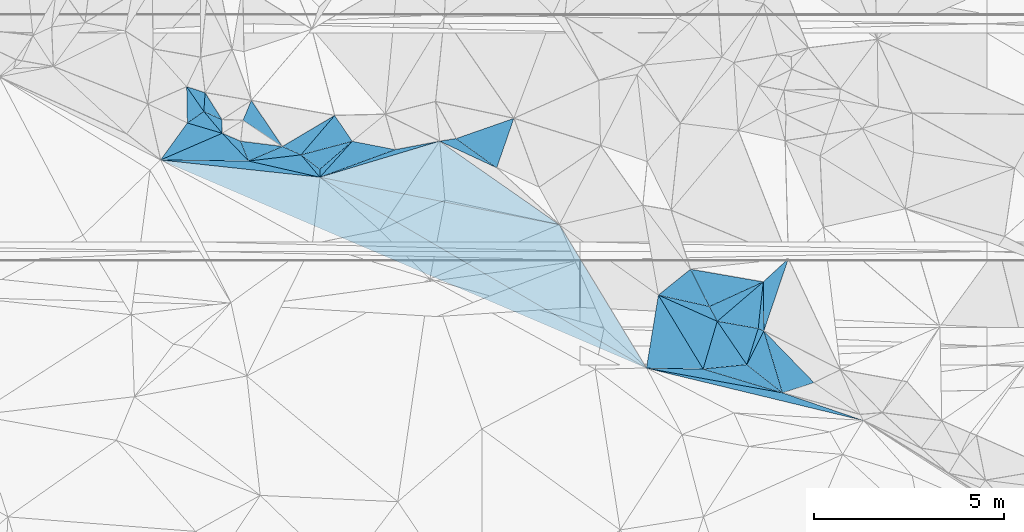
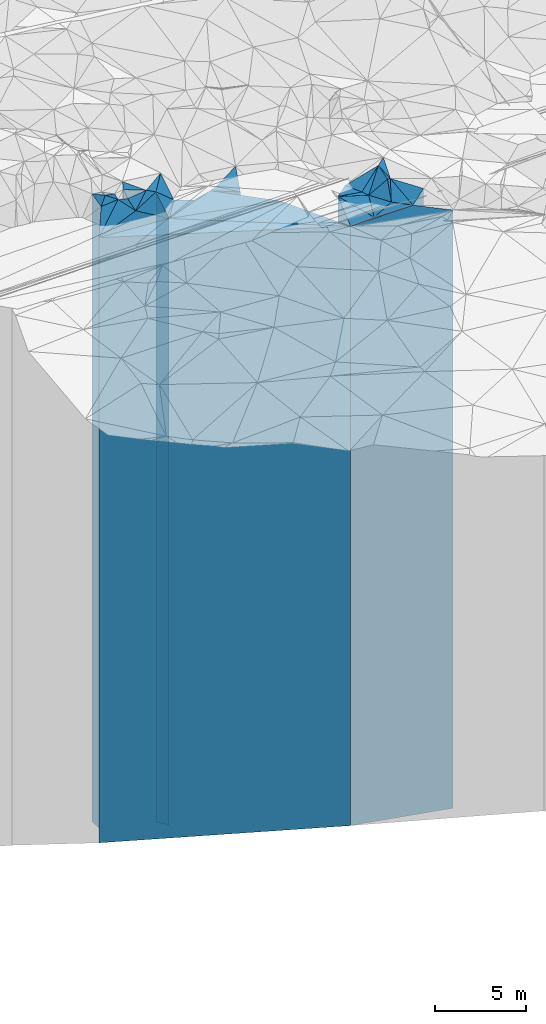
# One storey, part 203 of 275: 42 plates.
"""IFC2X3 building model written with IfcOpenShell, lengths in millimetres."""

from ifc_helpers import new_model, si_unit, frame, origin_with_axes, place, context, subcontext, project, spatial, faceted_brep, material, type_object, element, save


model = new_model("IFC2X3")

# Units and contexts
model_context = context("Model", 3, precision=1e-05, world=origin_with_axes())
body_context = subcontext(model_context, "Body", "Model", "MODEL_VIEW")
ifc_project = project(units=[si_unit("LENGTHUNIT", "METRE", prefix="MILLI"), si_unit("AREAUNIT", "SQUARE_METRE"), si_unit("VOLUMEUNIT", "CUBIC_METRE"), si_unit("MASSUNIT", "GRAM", prefix="KILO"), si_unit("TIMEUNIT", "SECOND"), si_unit("PLANEANGLEUNIT", "RADIAN"), si_unit("SOLIDANGLEUNIT", "STERADIAN"), si_unit("THERMODYNAMICTEMPERATUREUNIT", "DEGREE_CELSIUS"), si_unit("LUMINOUSINTENSITYUNIT", "LUMEN")], contexts=[model_context])

# Site, building, storey
site_placement = place(None, origin_with_axes())
site = spatial("IfcSite", under=ifc_project, at=site_placement, CompositionType="ELEMENT")
building_placement = place(site_placement, origin_with_axes())
building = spatial("IfcBuilding", under=site, at=building_placement, Name="Undefined", CompositionType="ELEMENT")
storey_placement = place(building_placement, origin_with_axes())
storey = spatial("IfcBuildingStorey", under=building, at=storey_placement, Name="Undefined", CompositionType="ELEMENT", Elevation=0.0)

# Plates
ifc_material = material()
plate_type_1 = type_object("IfcPlateType", PredefinedType="NOTDEFINED")
plate_1_placement = place(storey_placement, frame((-116440.557137259, 57306.797620916, 27989.0), z_axis=(0.0998657489693365, -0.995000920694445, 0.0), x_axis=(-0.995000920694446, -0.0998657489693296, 0.0)))
element("IfcPlate", 1, at=plate_1_placement, inside=storey, type_object=plate_type_1, material=ifc_material, Name="00", context=body_context, shape_type="Brep", body=[
    faceted_brep([(1.45519152283669e-11, -20711.0, 0.0), (-861.923767089815, -20621.0, 833.239074707031), (-861.923767089815, 20161.0, 833.239074707031), (1.45519152283669e-11, 20161.0, 0.0), (1157.41088867189, -20161.0, 1.68802216649055e-09), (1157.41088867189, 20161.0, 1.68802216649055e-09)], [[[0, 1, 2, 3]], [[1, 4, 5, 2]], [[4, 0, 3, 5]], [[5, 3, 2]], [[4, 1, 0]]]),
])
plate_type_2 = type_object("IfcPlateType", PredefinedType="NOTDEFINED")
plate_2_placement = place(storey_placement, frame((-119085.105449758, 57214.4654874976, 27906.0), z_axis=(0.234761072015638, 0.972053105064774, 0.0), x_axis=(0.972053105064773, -0.234761072015644, 0.0)))
element("IfcPlate", 2, at=plate_2_placement, inside=storey, type_object=plate_type_2, material=ifc_material, Name="00", context=body_context, shape_type="Brep", body=[
    faceted_brep([(-1.45519152283669e-11, -20150.0, 3.63797880709171e-12), (3637.92602539061, -20704.0, 209.225769042976), (3637.92602539061, 20078.0, 209.225769042976), (2.91038304567337e-11, 20078.0, -1.45519152283669e-11), (5883.48193359374, -20078.0, -1.29148247651756e-09), (5883.48193359374, 20078.0, -1.29148247651756e-09)], [[[0, 1, 2, 3]], [[1, 4, 5, 2]], [[4, 0, 3, 5]], [[5, 3, 2]], [[4, 1, 0]]]),
])
plate_type_3 = type_object("IfcPlateType", PredefinedType="NOTDEFINED")
plate_3_placement = place(storey_placement, frame((-115991.097209185, 58194.3705886519, 28219.0), z_axis=(0.892134515534765, -0.451769859764406, 0.0), x_axis=(-0.451769859764408, -0.892134515534764, 0.0)))
element("IfcPlate", 3, at=plate_3_placement, inside=storey, type_object=plate_type_3, material=ifc_material, Name="00", context=body_context, shape_type="Brep", body=[
    faceted_brep([(-6.59383658785373e-12, -21371.0, 1.45519152283669e-11), (1232.70288085937, -20391.0, 1175.00793457033), (1232.70288085937, 20391.0, 1175.00793457033), (-6.59383658785373e-12, 20391.0, 1.45519152283669e-11), (994.886901855462, -20481.0, 2.34285835176706e-09), (994.886901855462, 20391.0, 2.34285835176706e-09)], [[[0, 1, 2, 3]], [[1, 4, 5, 2]], [[4, 0, 3, 5]], [[5, 3, 2]], [[4, 1, 0]]]),
])
plate_type_4 = type_object("IfcPlateType", PredefinedType="NOTDEFINED")
plate_4_placement = place(storey_placement, frame((-118771.346950045, 59140.8965409895, 27942.0), z_axis=(0.986994799394878, -0.160752188064314, 0.0), x_axis=(-0.160752188064311, -0.986994799394879, 0.0)))
element("IfcPlate", 4, at=plate_4_placement, inside=storey, type_object=plate_type_4, material=ifc_material, Name="00", context=body_context, shape_type="Brep", body=[
    faceted_brep([(0.0, -20838.0, 0.0), (1734.77526855469, -20208.0, 1477.24572753906), (1734.77526855469, 20114.0, 1477.24572753906), (0.0, 20114.0, 0.0), (1951.81481933593, -20114.0, -2.79396772384644e-09), (1951.81481933593, 20114.0, -2.79396772384644e-09)], [[[0, 1, 2, 3]], [[1, 4, 5, 2]], [[4, 0, 3, 5]], [[5, 3, 2]], [[4, 1, 0]]]),
])
plate_type_5 = type_object("IfcPlateType", PredefinedType="NOTDEFINED")
plate_5_placement = place(storey_placement, frame((-115991.097209185, 58194.3705886519, 28709.0), z_axis=(-0.947058018121833, 0.321062471041301, 0.0), x_axis=(0.321062471041303, 0.947058018121832, 0.0)))
element("IfcPlate", 5, at=plate_5_placement, inside=storey, type_object=plate_type_5, material=ifc_material, Name="00", context=body_context, shape_type="Brep", body=[
    faceted_brep([(3.63797880709171e-12, -20881.0, 0.0), (1221.30859375, -20971.0, 429.657073974609), (1221.30859375, 20881.0, 429.657073974609), (3.63797880709171e-12, 20881.0, 0.0), (2009.97509765625, -20931.0, 1.78988557308912e-09), (2009.97509765625, 20881.0, 1.78988557308912e-09)], [[[0, 1, 2, 3]], [[1, 4, 5, 2]], [[4, 0, 3, 5]], [[5, 3, 2]], [[4, 1, 0]]]),
])
plate_type_6 = type_object("IfcPlateType", PredefinedType="NOTDEFINED")
plate_6_placement = place(storey_placement, frame((-117924.26484308, 59821.5961105942, 28309.0), z_axis=(0.891201122205586, 0.453608377104638, 0.0), x_axis=(0.453608377104646, -0.891201122205583, 0.0)))
element("IfcPlate", 6, at=plate_6_placement, inside=storey, type_object=plate_type_6, material=ifc_material, Name="00", context=body_context, shape_type="Brep", body=[
    faceted_brep([(-1.45519152283669e-11, -20511.0, 0.0), (1166.62939453122, -21371.0, 1558.77380371091), (1166.62939453122, 20481.0, 1558.77380371091), (-1.45519152283669e-11, 20481.0, 0.0), (1101.63513183592, -20481.0, 5.12227416038513e-09), (1101.63513183592, 20481.0, 5.12227416038513e-09)], [[[0, 1, 2, 3]], [[1, 4, 5, 2]], [[4, 0, 3, 5]], [[5, 3, 2]], [[4, 1, 0]]]),
])
plate_type_7 = type_object("IfcPlateType", PredefinedType="NOTDEFINED")
plate_7_placement = place(storey_placement, frame((-117924.26484308, 59821.5961105942, 28304.0), z_axis=(0.626395911836807, -0.77950507479691, 0.0), x_axis=(-0.779505074796912, -0.626395911836803, 0.0)))
element("IfcPlate", 7, at=plate_7_placement, inside=storey, type_object=plate_type_7, material=ifc_material, Name="00", context=body_context, shape_type="Brep", body=[
    faceted_brep([(1.45519152283669e-11, -20516.0, 1.45519152283669e-11), (225.4548187256, -20486.0, 1078.31823730472), (225.4548187256, 20476.0, 1078.31823730472), (0.0, 20476.0, 0.0), (1086.69226074221, -20476.0, 1.58615875989199e-09), (1086.69226074221, 20476.0, 1.58615875989199e-09)], [[[0, 1, 2, 3]], [[1, 4, 5, 2]], [[4, 0, 3, 5]], [[5, 3, 2]], [[4, 1, 0]]]),
])
plate_type_8 = type_object("IfcPlateType", PredefinedType="NOTDEFINED")
plate_8_placement = place(storey_placement, frame((-127694.000190885, 62455.7508581103, 28219.0), z_axis=(-0.654003369907349, 0.756491633892822, 0.0), x_axis=(0.756491633892824, 0.654003369907346, 0.0)))
element("IfcPlate", 8, at=plate_8_placement, inside=storey, type_object=plate_type_8, material=ifc_material, Name="00", context=body_context, shape_type="Brep", body=[
    faceted_brep([(0.0, -20391.0, 1.45519152283669e-11), (-126.185279846184, -21931.0, 613.658935546919), (-126.185279846184, 20391.0, 613.658935546919), (-6.59383658785373e-12, 20391.0, 1.45519152283669e-11), (1129.29187011719, -20691.0, 5.10772224515677e-09), (1129.29187011719, 20391.0, 5.10772224515677e-09)], [[[0, 1, 2, 3]], [[1, 4, 5, 2]], [[4, 0, 3, 5]], [[5, 3, 2]], [[4, 1, 0]]]),
])
plate_type_9 = type_object("IfcPlateType", PredefinedType="NOTDEFINED")
plate_9_placement = place(storey_placement, frame((-127694.000190885, 62455.7508581103, 28184.0), z_axis=(-0.609263113863359, -0.792968131822159, 0.0), x_axis=(-0.792968131822159, 0.609263113863359, 0.0)))
element("IfcPlate", 9, at=plate_9_placement, inside=storey, type_object=plate_type_9, material=ifc_material, Name="00", context=body_context, shape_type="Brep", body=[
    faceted_brep([(0.0, -20426.0, -1.45519152283669e-11), (-127.933326721191, -20356.0, 164.326095581055), (-127.933326721191, 20356.0, 164.326095581055), (0.0, 20356.0, -1.45519152283669e-11), (626.498229980469, -21966.0, -1.60071067512035e-09), (626.498229980469, 20356.0, -1.60071067512035e-09)], [[[0, 1, 2, 3]], [[1, 4, 5, 2]], [[4, 0, 3, 5]], [[5, 3, 2]], [[4, 1, 0]]]),
])
plate_type_10 = type_object("IfcPlateType", PredefinedType="NOTDEFINED")
plate_10_placement = place(storey_placement, frame((-123031.448124271, 62494.5867451311, 28184.0), z_axis=(-0.945001377387409, 0.327066349134086, 0.0), x_axis=(0.32706634913408, 0.945001377387411, 0.0)))
element("IfcPlate", 10, at=plate_10_placement, inside=storey, type_object=plate_type_10, material=ifc_material, Name="00", context=body_context, shape_type="Brep", body=[
    faceted_brep([(-1.09139364212751e-11, -20356.0, 0.0), (378.040496826154, -20626.0, 1267.11694335938), (378.040496826154, 20356.0, 1267.11694335938), (0.0, 20356.0, -1.45519152283669e-11), (1379.74633789061, -21146.0, 2.56113708019257e-09), (1379.74633789061, 20356.0, 2.56113708019257e-09)], [[[0, 1, 2, 3]], [[1, 4, 5, 2]], [[4, 0, 3, 5]], [[5, 3, 2]], [[4, 1, 0]]]),
])
plate_type_11 = type_object("IfcPlateType", PredefinedType="NOTDEFINED")
plate_11_placement = place(storey_placement, frame((-125703.944165359, 62974.8626141599, 28184.0), z_axis=(-0.189709514984272, -0.981840261918624, 0.0), x_axis=(-0.981840261918623, 0.189709514984278, 0.0)))
element("IfcPlate", 11, at=plate_11_placement, inside=storey, type_object=plate_type_11, material=ifc_material, Name="00", context=body_context, shape_type="Brep", body=[
    faceted_brep([(0.0, -20456.0, 1.45519152283669e-11), (1814.62451171875, -20356.0, 1091.43383789063), (1814.62451171875, 20356.0, 1091.43383789063), (0.0, 20356.0, -1.45519152283669e-11), (1156.7626953125, -20726.0, -8.22183210402727e-10), (1156.7626953125, 20356.0, -8.22183210402727e-10)], [[[0, 1, 2, 3]], [[1, 4, 5, 2]], [[4, 0, 3, 5]], [[5, 3, 2]], [[4, 1, 0]]]),
])
plate_type_12 = type_object("IfcPlateType", PredefinedType="NOTDEFINED")
plate_12_placement = place(storey_placement, frame((-127694.000190885, 62455.7508581103, 28184.0), z_axis=(0.999979630369262, 0.00638269900235852, 0.0), x_axis=(0.00638269900233659, -0.999979630369262, 0.0)))
element("IfcPlate", 12, at=plate_12_placement, inside=storey, type_object=plate_type_12, material=ifc_material, Name="00", context=body_context, shape_type="Brep", body=[
    faceted_brep([(0.0, -20426.0, -1.45519152283669e-11), (-733.092895507791, -20726.0, 858.996398925781), (-733.092895507791, 20356.0, 858.996398925781), (0.0, 20356.0, -1.45519152283669e-11), (208.254653930671, -20356.0, 7.27595761418343e-11), (208.254653930671, 20356.0, 7.27595761418343e-11)], [[[0, 1, 2, 3]], [[1, 4, 5, 2]], [[4, 0, 3, 5]], [[5, 3, 2]], [[4, 1, 0]]]),
])
plate_type_13 = type_object("IfcPlateType", PredefinedType="NOTDEFINED")
plate_13_placement = place(storey_placement, frame((-128681.802003754, 63057.7039945683, 29054.0), z_axis=(-0.828176731175873, -0.560467039119025, 0.0), x_axis=(-0.560467039119019, 0.828176731175876, 0.0)))
element("IfcPlate", 13, at=plate_13_placement, inside=storey, type_object=plate_type_13, material=ifc_material, Name="00", context=body_context, shape_type="Brep", body=[
    faceted_brep([(0.0, -21236.0, 1.45519152283669e-11), (1152.33959960938, -21226.0, 472.772216796875), (1152.33959960938, 21226.0, 472.772216796875), (0.0, 21226.0, 1.45519152283669e-11), (1463.28393554688, -21376.0, -2.13913153856993e-09), (1463.28393554688, 21226.0, -2.13913153856993e-09)], [[[0, 1, 2, 3]], [[1, 4, 5, 2]], [[4, 0, 3, 5]], [[5, 3, 2]], [[4, 1, 0]]]),
])
plate_type_14 = type_object("IfcPlateType", PredefinedType="NOTDEFINED")
plate_14_placement = place(storey_placement, frame((-131203.971896482, 64632.2385391942, 28899.0), z_axis=(0.821758074128353, 0.569836527089006, 0.0), x_axis=(0.56983652708901, -0.821758074128351, 0.0)))
element("IfcPlate", 14, at=plate_14_placement, inside=storey, type_object=plate_type_14, material=ifc_material, Name="00", context=body_context, shape_type="Brep", body=[
    faceted_brep([(0.0, -21071.0, 0.0), (405.644195556641, -21121.0, 308.954345703125), (405.644195556641, 21071.0, 308.954345703125), (0.0, 21071.0, 0.0), (794.292114257842, -21221.0, 6.33008312433958e-09), (794.292114257842, 21071.0, 6.33008312433958e-09)], [[[0, 1, 2, 3]], [[1, 4, 5, 2]], [[4, 0, 3, 5]], [[5, 3, 2]], [[4, 1, 0]]]),
])
plate_type_15 = type_object("IfcPlateType", PredefinedType="NOTDEFINED")
plate_15_placement = place(storey_placement, frame((-130718.935293339, 64474.9506070055, 28924.0), z_axis=(0.997865771497887, -0.0652985610325843, 0.0), x_axis=(-0.0652985610325673, -0.997865771497888, 0.0)))
element("IfcPlate", 15, at=plate_15_placement, inside=storey, type_object=plate_type_15, material=ifc_material, Name="00", context=body_context, shape_type="Brep", body=[
    faceted_brep([(-7.27595761418343e-12, -21096.0, 0.0), (679.976623535142, -21256.0, 490.848052978516), (679.976623535142, 21096.0, 490.848052978516), (0.0, 21096.0, 0.0), (496.48767089843, -21196.0, -4.07453626394272e-10), (496.48767089843, 21096.0, -4.07453626394272e-10)], [[[0, 1, 2, 3]], [[1, 4, 5, 2]], [[4, 0, 3, 5]], [[5, 3, 2]], [[4, 1, 0]]]),
])
plate_type_16 = type_object("IfcPlateType", PredefinedType="NOTDEFINED")
plate_16_placement = place(storey_placement, frame((-123031.448124271, 62494.5867451311, 28184.0), z_axis=(-0.583585493223676, -0.812051705311232, 0.0), x_axis=(-0.812051705311233, 0.583585493223674, 0.0)))
element("IfcPlate", 16, at=plate_16_placement, inside=storey, type_object=plate_type_16, material=ifc_material, Name="00", context=body_context, shape_type="Brep", body=[
    faceted_brep([(-1.09139364212751e-11, -20356.0, 0.0), (1631.82788085938, -20542.0, 307.575714111328), (1631.82788085938, 20356.0, 307.575714111328), (0.0, 20356.0, -1.45519152283669e-11), (1322.30859375, -20626.0, -3.26690496876836e-09), (1322.30859375, 20356.0, -3.26690496876836e-09)], [[[0, 1, 2, 3]], [[1, 4, 5, 2]], [[4, 0, 3, 5]], [[5, 3, 2]], [[4, 1, 0]]]),
])
plate_type_17 = type_object("IfcPlateType", PredefinedType="NOTDEFINED")
plate_17_placement = place(storey_placement, frame((-128681.802003754, 63057.7039945683, 28989.0), z_axis=(0.409277992984264, 0.91240973496493, 0.0), x_axis=(0.912409734964928, -0.409277992984267, 0.0)))
element("IfcPlate", 17, at=plate_17_placement, inside=storey, type_object=plate_type_17, material=ifc_material, Name="00", context=body_context, shape_type="Brep", body=[
    faceted_brep([(0.0, -21301.0, -4.54747350886464e-12), (922.428039550781, -21471.0, 1308.94104003906), (922.428039550781, 21161.0, 1308.94104003906), (0.0, 21161.0, -4.54747350886464e-12), (538.144958496094, -21161.0, 1.27602106658742e-09), (538.144958496094, 21161.0, 1.27602106658742e-09)], [[[0, 1, 2, 3]], [[1, 4, 5, 2]], [[4, 0, 3, 5]], [[5, 3, 2]], [[4, 1, 0]]]),
])
plate_type_18 = type_object("IfcPlateType", PredefinedType="NOTDEFINED")
plate_18_placement = place(storey_placement, frame((-131186.499208539, 63677.7781129972, 28764.0), z_axis=(-0.569836527089011, 0.82175807412835, 0.0), x_axis=(0.821758074128353, 0.569836527089006, 0.0)))
element("IfcPlate", 18, at=plate_18_placement, inside=storey, type_object=plate_type_18, material=ifc_material, Name="00", context=body_context, shape_type="Brep", body=[
    faceted_brep([(9.09494701772928e-12, -20936.0, -1.45519152283669e-11), (529.528076171904, -21206.0, 794.292114257813), (529.528076171904, 20936.0, 794.292114257813), (0.0, 20936.0, 1.45519152283669e-11), (529.52807617189, -21356.0, -2.31375452131033e-09), (529.52807617189, 20936.0, -2.31375452131033e-09)], [[[0, 1, 2, 3]], [[1, 4, 5, 2]], [[4, 0, 3, 5]], [[5, 3, 2]], [[4, 1, 0]]]),
])
plate_type_19 = type_object("IfcPlateType", PredefinedType="NOTDEFINED")
plate_19_placement = place(storey_placement, frame((-125703.944165359, 62974.8626141599, 28184.0), z_axis=(0.343489563862729, -0.939156493624674, 0.0), x_axis=(-0.939156493624675, -0.343489563862727, 0.0)))
element("IfcPlate", 19, at=plate_19_placement, inside=storey, type_object=plate_type_19, material=ifc_material, Name="00", context=body_context, shape_type="Brep", body=[
    faceted_brep([(0.0, -20456.0, 1.45519152283669e-11), (-1173.16003417967, -20542.0, 192.407135009766), (-1173.16003417967, 20356.0, 192.407135009766), (0.0, 20356.0, -1.45519152283669e-11), (2117.56689453126, -20356.0, -4.83123585581779e-09), (2117.56689453126, 20356.0, -4.83123585581779e-09)], [[[0, 1, 2, 3]], [[1, 4, 5, 2]], [[4, 0, 3, 5]], [[5, 3, 2]], [[4, 1, 0]]]),
])
plate_type_20 = type_object("IfcPlateType", PredefinedType="NOTDEFINED")
plate_20_placement = place(storey_placement, frame((-116005.890999821, 59488.967492618, 28284.0), z_axis=(0.416087513134234, -0.909324574293343, 0.0), x_axis=(-0.909324574293344, -0.41608751313423, 0.0)))
element("IfcPlate", 20, at=plate_20_placement, inside=storey, type_object=plate_type_20, material=ifc_material, Name="00", context=body_context, shape_type="Brep", body=[
    faceted_brep([(0.0, -21396.0, 0.0), (1535.77124023438, -20456.0, 440.348419189439), (1535.77124023438, 20456.0, 440.348419189439), (1.45519152283669e-11, 20456.0, 0.0), (1560.12817382814, -20506.0, 1.67347025126219e-09), (1560.12817382814, 20456.0, 1.67347025126219e-09)], [[[0, 1, 2, 3]], [[1, 4, 5, 2]], [[4, 0, 3, 5]], [[5, 3, 2]], [[4, 1, 0]]]),
])
plate_type_21 = type_object("IfcPlateType", PredefinedType="NOTDEFINED")
plate_21_placement = place(storey_placement, frame((-116440.557137259, 57306.797620916, 28264.0), z_axis=(-0.892134515534765, 0.451769859764406, 0.0), x_axis=(0.451769859764411, 0.892134515534762, 0.0)))
element("IfcPlate", 21, at=plate_21_placement, inside=storey, type_object=plate_type_21, material=ifc_material, Name="00", context=body_context, shape_type="Brep", body=[
    faceted_brep([(-9.09494701772928e-13, -20436.0, 1.45519152283669e-11), (985.740173339836, -21286.0, 162.531036376953), (985.740173339836, 20436.0, 162.531036376953), (-9.09494701772928e-13, 20436.0, 1.45519152283669e-11), (994.886901855461, -21326.0, 2.34285835176706e-09), (994.886901855461, 20436.0, 2.34285835176706e-09)], [[[0, 1, 2, 3]], [[1, 4, 5, 2]], [[4, 0, 3, 5]], [[5, 3, 2]], [[4, 1, 0]]]),
])
plate_type_22 = type_object("IfcPlateType", PredefinedType="NOTDEFINED")
plate_22_placement = place(storey_placement, frame((-117424.553911201, 58839.8176302026, 28284.0), z_axis=(-0.21816739609184, -0.975911362410801, 0.0), x_axis=(-0.975911362410803, 0.218167396091835, 0.0)))
element("IfcPlate", 22, at=plate_22_placement, inside=storey, type_object=plate_type_22, material=ifc_material, Name="00", context=body_context, shape_type="Brep", body=[
    faceted_brep([(2.91038304567337e-11, -20506.0, 0.0), (-285.572204589815, -20456.0, 336.078124999996), (-285.572204589815, 20456.0, 336.078124999996), (1.45519152283669e-11, 20456.0, 0.0), (1380.03625488283, -20496.0, 1.52067514136434e-09), (1380.03625488283, 20456.0, 1.52067514136434e-09)], [[[0, 1, 2, 3]], [[1, 4, 5, 2]], [[4, 0, 3, 5]], [[5, 3, 2]], [[4, 1, 0]]]),
])
plate_type_23 = type_object("IfcPlateType", PredefinedType="NOTDEFINED")
plate_23_placement = place(storey_placement, frame((-115499.730121397, 56563.8006315393, 28219.0), z_axis=(-0.30813975003277, 0.951341103101165, 0.0), x_axis=(0.951341103101166, 0.308139750032769, 0.0)))
element("IfcPlate", 23, at=plate_23_placement, inside=storey, type_object=plate_type_23, material=ifc_material, Name="00", context=body_context, shape_type="Brep", body=[
    faceted_brep([(0.0, -20391.0, 1.45519152283669e-11), (34.985710144043, -21371.0, 1702.63793945314), (34.985710144043, 20391.0, 1702.63793945314), (-6.59383658785373e-12, 20391.0, 1.45519152283669e-11), (874.642761230454, -21061.0, 5.16592990607023e-09), (874.642761230454, 20391.0, 5.16592990607023e-09)], [[[0, 1, 2, 3]], [[1, 4, 5, 2]], [[4, 0, 3, 5]], [[5, 3, 2]], [[4, 1, 0]]]),
])
plate_type_24 = type_object("IfcPlateType", PredefinedType="NOTDEFINED")
plate_24_placement = place(storey_placement, frame((-116140.228987553, 58259.637063054, 28264.0), z_axis=(-0.173335685932915, -0.984862802618804, 0.0), x_axis=(-0.984862802618805, 0.173335685932912, 0.0)))
element("IfcPlate", 24, at=plate_24_placement, inside=storey, type_object=plate_type_24, material=ifc_material, Name="00", context=body_context, shape_type="Brep", body=[
    faceted_brep([(3.63797880709171e-12, -21286.0, 0.0), (130.620941162124, -20436.0, 990.473693847664), (130.620941162124, 20436.0, 990.473693847664), (-9.09494701772928e-13, 20436.0, 1.45519152283669e-11), (1095.53637695314, -20476.0, 5.3114490583539e-10), (1095.53637695314, 20436.0, 5.3114490583539e-10)], [[[0, 1, 2, 3]], [[1, 4, 5, 2]], [[4, 0, 3, 5]], [[5, 3, 2]], [[4, 1, 0]]]),
])
plate_type_25 = type_object("IfcPlateType", PredefinedType="NOTDEFINED")
plate_25_placement = place(storey_placement, frame((-117592.18205208, 57191.2119143367, 27989.0), z_axis=(-0.958764016827141, 0.28420337794876, 0.0), x_axis=(0.284203377948762, 0.958764016827141, 0.0)))
element("IfcPlate", 25, at=plate_25_placement, inside=storey, type_object=plate_type_25, material=ifc_material, Name="00", context=body_context, shape_type="Brep", body=[
    faceted_brep([(-3.63797880709171e-12, -20161.0, 0.0), (1534.16479492189, -20791.0, 1684.64782714844), (1534.16479492189, 20161.0, 1684.64782714844), (1.45519152283669e-11, 20161.0, 0.0), (1312.4404296875, -20751.0, -1.64436642080545e-09), (1312.4404296875, 20161.0, -1.64436642080545e-09)], [[[0, 1, 2, 3]], [[1, 4, 5, 2]], [[4, 0, 3, 5]], [[5, 3, 2]], [[4, 1, 0]]]),
])
plate_type_26 = type_object("IfcPlateType", PredefinedType="NOTDEFINED")
plate_26_placement = place(storey_placement, frame((-130268.127294694, 63405.9453926322, 28764.0), z_axis=(-0.764769558858016, -0.644303904880388, 0.0), x_axis=(-0.644303904880388, 0.764769558858016, 0.0)))
element("IfcPlate", 26, at=plate_26_placement, inside=storey, type_object=plate_type_26, material=ifc_material, Name="00", context=body_context, shape_type="Brep", body=[
    faceted_brep([(0.0, -21256.0, 0.0), (799.599975585938, -20936.0, 527.200012207039), (799.599975585938, 20936.0, 527.200012207039), (0.0, 20936.0, 1.45519152283669e-11), (750.0, -21356.0, 1.41153577715158e-09), (750.0, 20936.0, 1.41153577715158e-09)], [[[0, 1, 2, 3]], [[1, 4, 5, 2]], [[4, 0, 3, 5]], [[5, 3, 2]], [[4, 1, 0]]]),
])
plate_type_27 = type_object("IfcPlateType", PredefinedType="NOTDEFINED")
plate_27_placement = place(storey_placement, frame((-131186.499208539, 63677.7781129972, 28137.5), z_axis=(0.810281429077818, -0.586040959056284, 0.0), x_axis=(-0.586040959056282, -0.810281429077819, 0.0)))
element("IfcPlate", 27, at=plate_27_placement, inside=storey, type_object=plate_type_27, material=ifc_material, Name="00", context=body_context, shape_type="Brep", body=[
    faceted_brep([(-2.91038304567337e-11, -21562.5, -1.50066625792533e-11), (-317.942565917969, -21882.5, 903.444824218779), (-317.942565917969, 20309.5, 903.444824218779), (-2.91038304567337e-11, 20309.5, -1.50066625792533e-11), (1204.17980957031, -20309.5, 1.07393134385347e-08), (1204.17980957031, 20309.5, 1.07393134385347e-08)], [[[0, 1, 2, 3]], [[1, 4, 5, 2]], [[4, 0, 3, 5]], [[5, 3, 2]], [[4, 1, 0]]]),
])
plate_type_28 = type_object("IfcPlateType", PredefinedType="NOTDEFINED")
plate_28_placement = place(storey_placement, frame((-129572.992320148, 62674.5854489906, 28644.0), z_axis=(-0.117022678958921, 0.993129242651367, 0.0), x_axis=(0.993129242651367, 0.117022678958922, 0.0)))
element("IfcPlate", 28, at=plate_28_placement, inside=storey, type_object=plate_type_28, material=ifc_material, Name="00", context=body_context, shape_type="Brep", body=[
    faceted_brep([(0.0, -20816.0, 0.0), (929.900695800781, -21646.0, 276.196746826172), (929.900695800781, 20816.0, 276.196746826172), (0.0, 20816.0, 0.0), (1391.76147460939, -21506.0, -1.32422428578138e-09), (1391.76147460939, 20816.0, -1.32422428578138e-09)], [[[0, 1, 2, 3]], [[1, 4, 5, 2]], [[4, 0, 3, 5]], [[5, 3, 2]], [[4, 1, 0]]]),
])
plate_type_29 = type_object("IfcPlateType", PredefinedType="NOTDEFINED")
plate_29_placement = place(storey_placement, frame((-129572.992320148, 62674.5854489906, 28184.0), z_axis=(0.221492508982198, 0.97516207292161, 0.0), x_axis=(0.97516207292161, -0.221492508982196, 0.0)))
element("IfcPlate", 29, at=plate_29_placement, inside=storey, type_object=plate_type_29, material=ifc_material, Name="00", context=body_context, shape_type="Brep", body=[
    faceted_brep([(0.0, -21276.0, 0.0), (1311.79406738278, -21966.0, 464.969085693356), (1311.79406738278, 20356.0, 464.969085693356), (0.0, 20356.0, -1.45519152283669e-11), (1928.21423339841, -20356.0, 8.5601641330868e-09), (1928.21423339841, 20356.0, 8.5601641330868e-09)], [[[0, 1, 2, 3]], [[1, 4, 5, 2]], [[4, 0, 3, 5]], [[5, 3, 2]], [[4, 1, 0]]]),
])
plate_type_30 = type_object("IfcPlateType", PredefinedType="NOTDEFINED")
plate_30_placement = place(storey_placement, frame((-117592.18205208, 57191.2119143367, 27989.0), z_axis=(-0.0998657489693365, 0.995000920694445, 0.0), x_axis=(0.995000920694446, 0.0998657489693296, 0.0)))
element("IfcPlate", 30, at=plate_30_placement, inside=storey, type_object=plate_type_30, material=ifc_material, Name="00", context=body_context, shape_type="Brep", body=[
    faceted_brep([(-3.63797880709171e-12, -20161.0, 0.0), (496.798492431641, -20751.0, 1214.78027343751), (496.798492431641, 20161.0, 1214.78027343751), (1.45519152283669e-11, 20161.0, 0.0), (1157.41088867188, -20711.0, 1.68802216649055e-09), (1157.41088867189, 20161.0, 1.68802216649055e-09)], [[[0, 1, 2, 3]], [[1, 4, 5, 2]], [[4, 0, 3, 5]], [[5, 3, 2]], [[4, 1, 0]]]),
])
plate_type_31 = type_object("IfcPlateType", PredefinedType="NOTDEFINED")
plate_31_placement = place(storey_placement, frame((-116005.890999821, 59488.967492618, 28689.0), z_axis=(0.994082177472656, -0.108630679051652, 0.0), x_axis=(-0.108630679051654, -0.994082177472656, 0.0)))
element("IfcPlate", 31, at=plate_31_placement, inside=storey, type_object=plate_type_31, material=ifc_material, Name="00", context=body_context, shape_type="Brep", body=[
    faceted_brep([(-1.45519152283669e-11, -20991.0, 0.0), (1285.32861328124, -20901.0, 155.33918762207), (1285.32861328124, 20861.0, 155.33918762207), (0.0, 20861.0, -1.45519152283669e-11), (1236.64868164062, -20861.0, 1.62981450557709e-09), (1236.64868164062, 20861.0, 1.62981450557709e-09)], [[[0, 1, 2, 3]], [[1, 4, 5, 2]], [[4, 0, 3, 5]], [[5, 3, 2]], [[4, 1, 0]]]),
])
plate_type_32 = type_object("IfcPlateType", PredefinedType="NOTDEFINED")
plate_32_placement = place(storey_placement, frame((-128681.802003754, 63057.7039945683, 28644.0), z_axis=(-0.123782575999795, -0.992309363998373, 0.0), x_axis=(-0.992309363998373, 0.123782575999795, 0.0)))
element("IfcPlate", 32, at=plate_32_placement, inside=storey, type_object=plate_type_32, material=ifc_material, Name="00", context=body_context, shape_type="Brep", body=[
    faceted_brep([(0.0, -21646.0, 1.45519152283669e-11), (836.9130859375, -20816.0, 490.485961914063), (836.9130859375, 20816.0, 490.485961914063), (0.0, 20816.0, 0.0), (1107.880859375, -21386.0, -2.8085196390748e-09), (1107.880859375, 20816.0, -2.8085196390748e-09)], [[[0, 1, 2, 3]], [[1, 4, 5, 2]], [[4, 0, 3, 5]], [[5, 3, 2]], [[4, 1, 0]]]),
])
plate_type_33 = type_object("IfcPlateType", PredefinedType="NOTDEFINED")
plate_33_placement = place(storey_placement, frame((-126839.700381449, 63194.3115093767, 28369.0), z_axis=(-0.82565764298637, -0.564171477990683, 0.0), x_axis=(-0.56417147799069, 0.825657642986365, 0.0)))
element("IfcPlate", 33, at=plate_33_placement, inside=storey, type_object=plate_type_33, material=ifc_material, Name="00", context=body_context, shape_type="Brep", body=[
    faceted_brep([(0.0, -20541.0, 0.0), (467.60522460936, -21781.0, 1316.86950683594), (467.60522460936, 20541.0, 1316.86950683594), (0.0, 20541.0, 0.0), (823.771789550767, -22091.0, -9.60426405072212e-10), (823.771789550767, 20541.0, -9.60426405072212e-10)], [[[0, 1, 2, 3]], [[1, 4, 5, 2]], [[4, 0, 3, 5]], [[5, 3, 2]], [[4, 1, 0]]]),
])
plate_type_34 = type_object("IfcPlateType", PredefinedType="NOTDEFINED")
plate_34_placement = place(storey_placement, frame((-131892.197895715, 62702.0535807047, 28137.5), z_axis=(0.0118429369995644, 0.999929869962501, 0.0), x_axis=(0.999929869962501, -0.0118429369995561, 0.0)))
element("IfcPlate", 34, at=plate_34_placement, inside=storey, type_object=plate_type_34, material=ifc_material, Name="00", context=body_context, shape_type="Brep", body=[
    faceted_brep([(0.0, -20309.5, 7.27595761418343e-12), (1615.62060546874, -21882.5, 723.076232910156), (1615.62060546874, 20309.5, 723.076232910156), (-2.91038304567337e-11, 20309.5, -1.50066625792533e-11), (2319.36816406249, -21322.5, -2.57205101661384e-08), (2319.36816406249, 20309.5, -2.57205101661384e-08)], [[[0, 1, 2, 3]], [[1, 4, 5, 2]], [[4, 0, 3, 5]], [[5, 3, 2]], [[4, 1, 0]]]),
])
plate_type_35 = type_object("IfcPlateType", PredefinedType="NOTDEFINED")
plate_35_placement = place(storey_placement, frame((-129572.992320148, 62674.5854489906, 28137.5), z_axis=(-0.0118429369995499, -0.999929869962501, 0.0), x_axis=(-0.999929869962501, 0.0118429369995563, 0.0)))
element("IfcPlate", 35, at=plate_35_placement, inside=storey, type_object=plate_type_35, material=ifc_material, Name="00", context=body_context, shape_type="Brep", body=[
    faceted_brep([(0.0, -21322.5, -7.27595761418343e-12), (-1885.24743652344, -20402.5, 404.786529541023), (-1885.24743652344, 20309.5, 404.786529541023), (-2.91038304567337e-11, 20309.5, -1.50066625792533e-11), (2319.36816406247, -20309.5, 8.41100700199604e-09), (2319.36816406249, 20309.5, -2.57205101661384e-08)], [[[0, 1, 2, 3]], [[1, 4, 5, 2]], [[4, 0, 3, 5]], [[5, 3, 2]], [[4, 1, 0]]]),
])
plate_type_36 = type_object("IfcPlateType", PredefinedType="NOTDEFINED")
plate_36_placement = place(storey_placement, frame((-130268.127294694, 63405.9453926322, 28924.0), z_axis=(-0.999886150771358, -0.015089250996547, 0.0), x_axis=(-0.0150892509965396, 0.999886150771358, 0.0)))
element("IfcPlate", 36, at=plate_36_placement, inside=storey, type_object=plate_type_36, material=ifc_material, Name="00", context=body_context, shape_type="Brep", body=[
    faceted_brep([(-7.27595761418343e-12, -21096.0, 0.0), (580.803405761726, -21196.0, 474.518066406265), (580.803405761726, 21096.0, 474.518066406265), (0.0, 21096.0, 0.0), (358.468963623054, -21256.0, -3.05590219795704e-10), (358.468963623054, 21096.0, -3.05590219795704e-10)], [[[0, 1, 2, 3]], [[1, 4, 5, 2]], [[4, 0, 3, 5]], [[5, 3, 2]], [[4, 1, 0]]]),
])
plate_type_37 = type_object("IfcPlateType", PredefinedType="NOTDEFINED")
plate_37_placement = place(storey_placement, frame((-119085.105449758, 57214.4654874976, 27942.0), z_axis=(-0.504765330930312, -0.863256601880816, 0.0), x_axis=(-0.863256601880816, 0.504765330930311, 0.0)))
element("IfcPlate", 37, at=plate_37_placement, inside=storey, type_object=plate_type_37, material=ifc_material, Name="00", context=body_context, shape_type="Brep", body=[
    faceted_brep([(-2.91038304567337e-11, -20114.0, -1.81898940354586e-12), (13825.7509765625, -20505.0, 1727.37963867187), (13825.7509765625, 20114.0, 1727.37963867187), (0.0, 20114.0, 0.0), (9971.03906249997, -20598.0, 3.51119524566457e-08), (9971.03906249997, 20114.0, 3.51119524566457e-08)], [[[0, 1, 2, 3]], [[1, 4, 5, 2]], [[4, 0, 3, 5]], [[5, 3, 2]], [[4, 1, 0]]]),
])
plate_type_38 = type_object("IfcPlateType", PredefinedType="NOTDEFINED")
plate_38_placement = place(storey_placement, frame((-121381.014890353, 60994.9200687069, 28051.0), z_axis=(-0.572357569853024, -0.820004153789443, 0.0), x_axis=(-0.82000415378944, 0.572357569853029, 0.0)))
element("IfcPlate", 38, at=plate_38_placement, inside=storey, type_object=plate_type_38, material=ifc_material, Name="00", context=body_context, shape_type="Brep", body=[
    faceted_brep([(2.91038304567337e-11, -20223.0, 3.63797880709171e-12), (5892.50830078128, -20489.0, 2585.40307617187), (5892.50830078128, 20223.0, 2585.40307617187), (0.0, 20223.0, 0.0), (3847.61279296878, -20675.0, 6.66841515339911e-09), (3847.61279296875, 20223.0, 6.65750121697783e-09)], [[[0, 1, 2, 3]], [[1, 4, 5, 2]], [[4, 0, 3, 5]], [[5, 3, 2]], [[4, 1, 0]]]),
])
plate_type_39 = type_object("IfcPlateType", PredefinedType="NOTDEFINED")
plate_39_placement = place(storey_placement, frame((-127692.670964037, 62247.5004483725, 27942.0), z_axis=(0.504765330930312, 0.863256601880816, 0.0), x_axis=(0.863256601880817, -0.50476533093031, 0.0)))
element("IfcPlate", 39, at=plate_39_placement, inside=storey, type_object=plate_type_39, material=ifc_material, Name="00", context=body_context, shape_type="Brep", body=[
    faceted_brep([(-2.91038304567337e-11, -20598.0, -1.2732925824821e-11), (6080.83789062497, -20332.0, 2104.60693359374), (6080.83789062497, 20114.0, 2104.60693359374), (0.0, 20114.0, 0.0), (9971.03906249997, -20114.0, 3.50937625626102e-08), (9971.03906249997, 20114.0, 3.51119524566457e-08)], [[[0, 1, 2, 3]], [[1, 4, 5, 2]], [[4, 0, 3, 5]], [[5, 3, 2]], [[4, 1, 0]]]),
])
plate_type_40 = type_object("IfcPlateType", PredefinedType="NOTDEFINED")
plate_40_placement = place(storey_placement, frame((-129781.162555324, 63194.8403415065, 28644.0), z_axis=(-0.397745432997045, -0.917495814993177, 0.0), x_axis=(-0.917495814993174, 0.397745432997052, 0.0)))
element("IfcPlate", 40, at=plate_40_placement, inside=storey, type_object=plate_type_40, material=ifc_material, Name="00", context=body_context, shape_type="Brep", body=[
    faceted_brep([(0.0, -21386.0, -6.3664629124105e-12), (-397.92431640625, -20816.0, 394.532928466783), (-397.92431640625, 20816.0, 394.532928466783), (0.0, 20816.0, 0.0), (530.754150390625, -21376.0, 1.07047526398674e-09), (530.754150390625, 20816.0, 1.07047526398674e-09)], [[[0, 1, 2, 3]], [[1, 4, 5, 2]], [[4, 0, 3, 5]], [[5, 3, 2]], [[4, 1, 0]]]),
])
plate_type_41 = type_object("IfcPlateType", PredefinedType="NOTDEFINED")
plate_41_placement = place(storey_placement, frame((-117219.18203523, 58449.5326156806, 28284.0), z_axis=(0.173335685932915, 0.984862802618804, 0.0), x_axis=(0.984862802618805, -0.17333568593291, 0.0)))
element("IfcPlate", 41, at=plate_41_placement, inside=storey, type_object=plate_type_41, material=ifc_material, Name="00", context=body_context, shape_type="Brep", body=[
    faceted_brep([(0.0, -20456.0, 1.45519152283669e-11), (1014.75402832031, -21396.0, 1234.00732421876), (1014.75402832031, 20456.0, 1234.00732421876), (1.45519152283669e-11, 20456.0, 0.0), (1095.53637695314, -21266.0, 5.3114490583539e-10), (1095.53637695314, 20456.0, 5.3114490583539e-10)], [[[0, 1, 2, 3]], [[1, 4, 5, 2]], [[4, 0, 3, 5]], [[5, 3, 2]], [[4, 1, 0]]]),
])
plate_type_42 = type_object("IfcPlateType", PredefinedType="NOTDEFINED")
plate_42_placement = place(storey_placement, frame((-115499.730121397, 56563.8006315393, 27942.0), z_axis=(-0.287211686147574, -0.957867134492184, 0.0), x_axis=(-0.957867134492183, 0.287211686147578, 0.0)))
element("IfcPlate", 42, at=plate_42_placement, inside=storey, type_object=plate_type_42, material=ifc_material, Name="00", context=body_context, shape_type="Brep", body=[
    faceted_brep([(2.91038304567337e-11, -20668.0, -3.63797880709171e-12), (3621.19165039064, -20114.0, 406.511199951168), (3621.19165039064, 20114.0, 406.511199951168), (0.0, 20114.0, 0.0), (2184.49072265628, -20208.0, 8.50195647217333e-09), (2184.49072265628, 20114.0, 8.50195647217333e-09)], [[[0, 1, 2, 3]], [[1, 4, 5, 2]], [[4, 0, 3, 5]], [[5, 3, 2]], [[4, 1, 0]]]),
])

save(model, "model.ifc")
